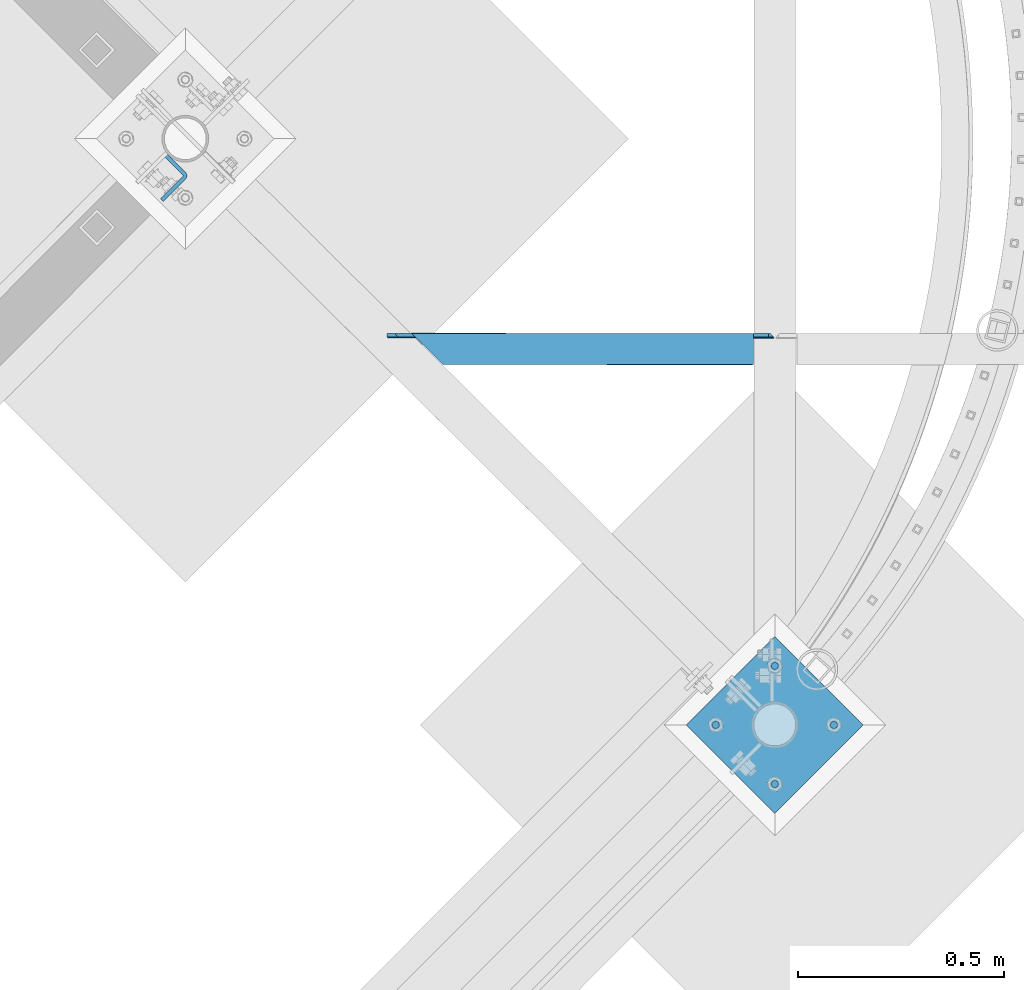
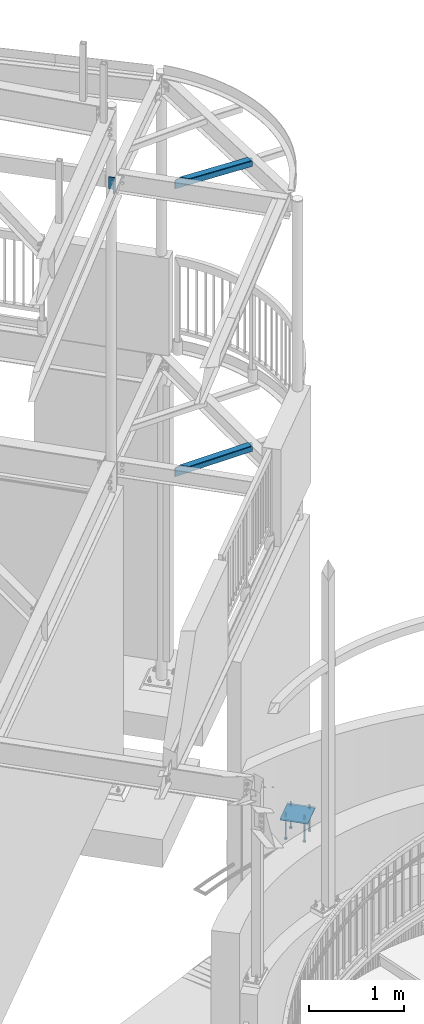
# One storey, part 520 of 975: 9 beams.
"""IFC2X3 building model written with IfcOpenShell, lengths in millimetres."""

import ifcopenshell
import ifcopenshell.guid

model = None  # the IFC model being written
_history = None  # IfcOwnerHistory: only IFC2X3 demands one
_inside = {}  # id of a spatial element -> (the spatial element, [elements in it])
_under = {}  # id of a project, library or spatial element -> (it, [spatial elements below it])
_declared = {}  # id of a project -> (the project, [libraries it declares])
_typed = {}  # id of a type object -> (the type object, [elements of that type])
_made_of = {}  # id of a material, layer set ... -> (it, [elements and type objects made of it])


def new_model(schema):
    """Start an empty IFC model of exactly this schema.

    Asked for "IFC4X3", IfcOpenShell would pick the latest addendum, in which some entities
    have other attributes; the version numbers below select the first issue.
    IFC2X3 requires an IfcOwnerHistory on every rooted entity: one is made here for all.
    """
    global model, _history
    if schema == "IFC4X3":
        model = ifcopenshell.file(schema_version=(4, 3, 0, 0))
    else:
        model = ifcopenshell.file(schema=schema)
    _inside.clear()
    _under.clear()
    _declared.clear()
    _typed.clear()
    _made_of.clear()
    _history = None
    if model.schema == "IFC2X3":
        org = make("IfcOrganization", Name="unknown")
        user = make(
            "IfcPersonAndOrganization",
            ThePerson=make("IfcPerson", FamilyName="unknown"),
            TheOrganization=org,
        )
        app = make(
            "IfcApplication",
            ApplicationDeveloper=org,
            Version="unknown",
            ApplicationFullName="unknown",
            ApplicationIdentifier="unknown",
        )
        _history = make(
            "IfcOwnerHistory",
            OwningUser=user,
            OwningApplication=app,
            ChangeAction="ADDED",
            CreationDate=0,
        )
    return model


def make(cls, **values):
    """One entity of the class cls with the attributes given. An attribute that is None is left unset."""
    return model.create_entity(
        cls, **{name: value for name, value in values.items() if value is not None}
    )


def rooted(cls, **values):
    """An entity with a GlobalId (a new one), such as an element, a storey or a relation."""
    return make(cls, GlobalId=ifcopenshell.guid.new(), OwnerHistory=_history, **values)


def si_unit(unit_type, name, prefix=None):
    """IfcSIUnit, for example si_unit("LENGTHUNIT", "METRE", prefix="MILLI")."""
    return make("IfcSIUnit", UnitType=unit_type, Prefix=prefix, Name=name)


def assignment(units):
    """IfcUnitAssignment: the units of a project."""
    return None if units is None else make("IfcUnitAssignment", Units=units)


def point(xyz):
    """IfcCartesianPoint."""
    return None if xyz is None else make("IfcCartesianPoint", Coordinates=xyz)


def direction(xyz):
    """IfcDirection."""
    return None if xyz is None else make("IfcDirection", DirectionRatios=xyz)


def frame(location, z_axis=None, x_axis=None):
    """IfcAxis2Placement3D, a coordinate frame: its origin and axes. An axis left out is left unset."""
    return make(
        "IfcAxis2Placement3D",
        Location=point(location),
        Axis=direction(z_axis),
        RefDirection=direction(x_axis),
    )


def origin_with_axes():
    """The frame at (0, 0, 0) with the z axis (0, 0, 1) and the x axis (1, 0, 0) written out."""
    return frame((0.0, 0.0, 0.0), z_axis=(0.0, 0.0, 1.0), x_axis=(1.0, 0.0, 0.0))


def place(relative_to, where):
    """IfcLocalPlacement: puts the frame where relative to a parent placement (None: the world)."""
    return make(
        "IfcLocalPlacement", PlacementRelTo=relative_to, RelativePlacement=where
    )


def context(
    kind, dimensions, precision=None, world=None, true_north=None, identifier=None
):
    """IfcGeometricRepresentationContext, for example the 3D "Model" context."""
    return make(
        "IfcGeometricRepresentationContext",
        ContextIdentifier=identifier,
        ContextType=kind,
        CoordinateSpaceDimension=dimensions,
        Precision=precision,
        WorldCoordinateSystem=world,
        TrueNorth=true_north,
    )


def subcontext(parent, identifier, kind, view, scale=None):
    """IfcGeometricRepresentationSubContext, for example "Body" below "Model"."""
    return make(
        "IfcGeometricRepresentationSubContext",
        ContextIdentifier=identifier,
        ContextType=kind,
        ParentContext=parent,
        TargetScale=scale,
        TargetView=view,
    )


def project(units=None, contexts=None):
    """IfcProject with its units and contexts."""
    return rooted(
        "IfcProject",
        Name="project",
        RepresentationContexts=contexts,
        UnitsInContext=assignment(units),
    )


def spatial(cls, under=None, at=None, **own):
    """A site, building, storey or space (cls), placed at a placement, below another one or the project."""
    s = rooted(cls, ObjectPlacement=at, **own)
    if under is not None:
        _under.setdefault(under.id(), (under, []))[1].append(s)
    return s


def faces_of(points, faces, orient=None, outer=None):
    """IfcFace entities. A face is a list of loops; a loop is a list of indices into points, from 0.

    orient and outer hold one flag for each loop. By default every Orientation is true, the
    first loop of a face is its IfcFaceOuterBound and the others are IfcFaceBound.
    """
    made = []
    for i, loops in enumerate(faces):
        bounds = []
        for j, loop in enumerate(loops):
            is_outer = j == 0 if outer is None else outer[i][j]
            bounds.append(
                make(
                    "IfcFaceOuterBound" if is_outer else "IfcFaceBound",
                    Bound=make("IfcPolyLoop", Polygon=[points[k] for k in loop]),
                    Orientation=True if orient is None else orient[i][j],
                )
            )
        made.append(make("IfcFace", Bounds=bounds))
    return made


def faceted_brep(points, faces, orient=None, outer=None, voids=None):
    """IfcFacetedBrep: a solid bounded by flat faces; with voids (closed shells), ...WithVoids."""
    shared = [point(p) for p in points]
    hull = make("IfcClosedShell", CfsFaces=faces_of(shared, faces, orient, outer))
    if voids is None:
        return make("IfcFacetedBrep", Outer=hull)
    return make(
        "IfcFacetedBrepWithVoids",
        Outer=hull,
        Voids=[
            make(cls, CfsFaces=faces_of(shared, fs, o, b)) for cls, fs, o, b in voids
        ],
    )


def shape(context_of_items, identifier, shape_type, items):
    """IfcShapeRepresentation: the items that make up one representation, for example the "Body"."""
    return make(
        "IfcShapeRepresentation",
        ContextOfItems=context_of_items,
        RepresentationIdentifier=identifier,
        RepresentationType=shape_type,
        Items=items,
    )


def material(Name=None, Category=None):
    """IfcMaterial."""
    return make("IfcMaterial", Name=Name, Category=Category)


def made_of(thing, what):
    """Note that an element or type object is made of a material, layer set ...; save() writes the relation."""
    if what is not None:
        _made_of.setdefault(what.id(), (what, []))[1].append(thing)
    return thing


def type_object(cls, material=None, **own):
    """A type object (cls), such as IfcWallType, which elements share."""
    return made_of(rooted(cls, **own), material)


def element(
    cls,
    number,
    at=None,
    inside=None,
    cuts=None,
    type_object=None,
    material=None,
    context=None,
    identifier="Body",
    shape_type=None,
    held_by="IfcProductDefinitionShape",
    body=None,
    shapes=None,
    **own,
):
    """One element of the class cls, such as IfcWall. Its Tag is "e" and its number.

    at: its placement. inside: the storey or other place that contains it. cuts: it is an
    opening in that element (IfcRelVoidsElement). A single representation is given by context,
    identifier, shape_type and body (its items); several are given by shapes. held_by: the class
    of the entity that holds the representations. save() writes the other relations.
    """
    e = rooted(cls, Tag="e%d" % number, ObjectPlacement=at, **own)
    if body is not None:
        shapes = [shape(context, identifier, shape_type, body)]
    if shapes is not None:
        e.Representation = make(held_by, Representations=shapes)
    if inside is not None:
        _inside.setdefault(inside.id(), (inside, []))[1].append(e)
    if cuts is not None:
        rooted(
            "IfcRelVoidsElement", RelatingBuildingElement=cuts, RelatedOpeningElement=e
        )
    if type_object is not None:
        _typed.setdefault(type_object.id(), (type_object, []))[1].append(e)
    return made_of(e, material)


def aggregate(whole, parts):
    """IfcRelAggregates: a whole, such as a stair, and the parts it consists of."""
    return rooted("IfcRelAggregates", RelatingObject=whole, RelatedObjects=parts)


def save(model, path):
    """Write the relations noted so far, then the file.

    IfcRelAggregates (storeys below a building ...), IfcRelContainedInSpatialStructure (elements
    in a storey), IfcRelDefinesByType, IfcRelAssociatesMaterial and IfcRelDeclares: one each for
    every whole, place, type object, material and project.
    """
    for whole, parts in _under.values():
        aggregate(whole, parts)
    for where, things in _inside.values():
        rooted(
            "IfcRelContainedInSpatialStructure",
            RelatedElements=things,
            RelatingStructure=where,
        )
    for kind, things in _typed.values():
        rooted("IfcRelDefinesByType", RelatedObjects=things, RelatingType=kind)
    for what, things in _made_of.values():
        rooted("IfcRelAssociatesMaterial", RelatedObjects=things, RelatingMaterial=what)
    for by, libraries in _declared.values():
        rooted("IfcRelDeclares", RelatingContext=by, RelatedDefinitions=libraries)
    model.write(path)


model = new_model("IFC2X3")

# Units and contexts
model_context = context("Model", 3, precision=1e-05, world=origin_with_axes())
body_context = subcontext(model_context, "Body", "Model", "MODEL_VIEW")
ifc_project = project(units=[si_unit("LENGTHUNIT", "METRE", prefix="MILLI"), si_unit("AREAUNIT", "SQUARE_METRE"), si_unit("VOLUMEUNIT", "CUBIC_METRE"), si_unit("MASSUNIT", "GRAM", prefix="KILO"), si_unit("TIMEUNIT", "SECOND"), si_unit("PLANEANGLEUNIT", "RADIAN"), si_unit("SOLIDANGLEUNIT", "STERADIAN"), si_unit("THERMODYNAMICTEMPERATUREUNIT", "DEGREE_CELSIUS"), si_unit("LUMINOUSINTENSITYUNIT", "LUMEN")], contexts=[model_context])

# Site, building, storey
site_placement = place(None, origin_with_axes())
site = spatial("IfcSite", under=ifc_project, at=site_placement, CompositionType="ELEMENT")
building_placement = place(site_placement, origin_with_axes())
building = spatial("IfcBuilding", under=site, at=building_placement, Name="Undefined", CompositionType="ELEMENT")
storey_placement = place(building_placement, origin_with_axes())
storey = spatial("IfcBuildingStorey", under=building, at=storey_placement, Name="Undefined", CompositionType="ELEMENT", Elevation=0.0)

# Beams
ifc_material_1 = material(Name="STEEL/A36")
beam_type_1 = type_object("IfcBeamType", Name="L5X3X3/8", PredefinedType="NOTDEFINED")
beam_1_placement = place(storey_placement, frame((35537.7749999864, 11155.2515974381, 3873.5), z_axis=(0.0, 0.0, -1.0), x_axis=(-0.999999999999998, 6.90000001668524e-08, 0.0)))
element("IfcBeam", 1, at=beam_1_placement, inside=storey, type_object=beam_type_1, material=ifc_material_1, Name="ANGLE", ObjectType="L5X3X3/8", context=body_context, shape_type="Brep", body=[
    faceted_brep([(11.9062518201463, 38.1000002942765, 63.5000000000409), (11.9062518201463, 38.1000000000004, -50.8000004849969), (2.38125152588327, 28.5750000000007, -41.2750001907348), (2.38125152588327, 28.5750000000007, 63.5), (52.3875000000044, -38.1000000000004, -53.9749999999999), (52.3875000000044, -38.1000000000004, -63.5), (806.831932706991, -38.1000000000004, -63.5), (806.831932706991, -38.1000000000004, -53.9749999999999), (52.3875000000044, 28.5750000000007, -53.9749999999999), (873.882778224608, 28.5750000000007, -53.9749999999999), (15.0812513351484, 28.5750000000007, -53.9749999999999), (15.0812513351484, 38.1000000000004, -53.9749999999999), (52.3875000000044, 38.1000000000004, -53.9749999999999), (52.3875000000044, 38.1000000000004, -63.5), (883.461470441413, 38.1000000000004, -63.5), (883.461470441413, 38.1000000000004, -53.9750003774025), (925.242134563909, 38.1000000000004, -51.077271348563), (915.663442347111, 28.5750000000007, -51.077271348563), (942.550496853299, 38.1000000000004, -37.6135273571017), (942.550497938631, 28.5750000000007, -30.1625003774025), (942.550496853299, 28.5750000000007, 63.5), (942.550496853299, 38.1000000000004, 63.5000000040263)], [[[0, 1, 2, 3]], [[4, 5, 6, 7]], [[8, 4, 7, 9]], [[10, 11, 12, 8]], [[4, 8, 12, 13, 5]], [[5, 13, 14, 6]], [[15, 9, 7, 6, 14]], [[16, 17, 9, 15]], [[17, 16, 18, 19]], [[20, 19, 18, 21]], [[20, 21, 0, 3]], [[10, 8, 9, 17, 19, 20, 3, 2]], [[11, 10, 2, 1]], [[21, 18, 16, 15, 14, 13, 12, 11, 1, 0]]]),
])
beam_2_placement = place(storey_placement, frame((35535.0920992425, 11153.5144184146, 7523.50181482672), z_axis=(-0.0422504062137741, -0.0209237200044117, -0.99888793221059), x_axis=(-0.999107052910133, 0.000884825999921025, 0.0422411399962006)))
element("IfcBeam", 2, at=beam_2_placement, inside=storey, type_object=beam_type_1, material=ifc_material_1, Name="ANGLE", ObjectType="L5X3X3/8", context=body_context, shape_type="Brep", body=[
    faceted_brep([(941.742880196944, 38.0999993124042, -35.9725623119593), (937.536367839362, 38.1000000003914, 63.5000000001819), (937.536368026471, 28.5750000003973, 63.5000000001783), (941.457524557751, 28.5750000004664, -29.2247304156172), (53.4452887239022, -38.0999999999149, -53.9750000000258), (53.8480835175287, -38.0999999999094, -63.5000000000291), (807.064276355675, -38.099999999542, -63.4999999999145), (807.06427633432, -38.0999999995493, -53.9749999999094), (53.4452887390871, 28.5750000000535, -53.9750000000022), (874.050649366603, 28.5750000004518, -53.9749999998785), (48.4726977129612, 28.5749999999625, 63.50000000004), (48.4726978208564, 38.0999999999567, 63.5000000000437), (6.6211369338489, 38.0999999999403, 61.7301741910833), (-2.89535803997569, 28.5749999999389, 61.3277390639887), (11.2222354366604, 38.1000002997298, -47.0732759403381), (1.30330533162487, 28.5750000000153, -37.9592161034652), (13.6967584280574, 38.1000000000258, -49.3470040937027), (13.696758414997, 28.5750000000298, -49.3470040896955), (53.1789736611245, 38.100000000044, -47.6773735700881), (53.1789736587452, 28.575000000048, -47.6773735656316), (53.8480835348819, 38.1000000000568, -63.5000000000036), (883.62013121794, 38.1000000004587, -63.4999999998763), (883.620131173593, 38.0999999520591, -50.7375928477722), (874.050649363482, 28.57500000045, -51.1422686872647), (924.840126222451, 38.0999999463384, -48.9944748163671), (915.270644418095, 28.5750000004682, -49.3991506556158)], [[[0, 1, 2, 3]], [[4, 5, 6, 7]], [[8, 4, 7, 9]], [[10, 11, 12, 13]], [[14, 15, 13, 12]], [[16, 17, 15, 14]], [[18, 19, 17, 16]], [[5, 4, 8, 19, 18, 20]], [[5, 20, 21, 6]], [[22, 23, 9, 7, 6, 21]], [[24, 25, 23, 22]], [[25, 24, 0, 3]], [[10, 13, 15, 17, 19, 8, 9, 23, 25, 3, 2]], [[11, 10, 2, 1]], [[24, 22, 21, 20, 18, 16, 14, 12, 11, 1, 0]]]),
])
beam_type_2 = type_object("IfcBeamType", PredefinedType="NOTDEFINED")
beam_3_placement = place(storey_placement, frame((34052.9424595516, 11630.2526601364, 7499.36613405322), z_axis=(0.0, 0.0, 1.0), x_axis=(0.709329753904792, -0.704876797905398, 0.0)))
element("IfcBeam", 3, at=beam_3_placement, inside=storey, type_object=beam_type_2, material=ifc_material_1, Name="PLATE", context=body_context, shape_type="Brep", body=[
    faceted_brep([(-1.26819941215217e-07, 4.76250000000437, -76.1999999999998), (-1.26819941215217e-07, 4.76250000000437, 76.1999999999998), (67.9764954378516, 4.76250083879131, 76.1999999999998), (67.9764954378516, 4.76250083879131, -76.1999999999998), (1.26819941215217e-07, -4.762500000008, 76.1999999999998), (1.26819941215217e-07, -4.762500000008, -76.1999999999998), (67.9764955554074, -4.76249916121378, -76.1999999999998), (67.9764955554074, -4.76249916121378, 76.1999999999998), (74.3264952113022, 3.0610236584871, 76.1999999999998), (74.3264952113022, 3.0610236584871, -76.1999999999998), (69.5639954269482, -5.18786843704584, -76.1999999999998), (69.5639954269482, -5.18786843704584, 76.1999999999998), (70.7261260223277, -6.34999895563669, -76.1999999999998), (70.7261260223277, -6.34999895563669, 76.1999999999998), (78.9750178031391, -1.58749862619516, 76.1999999999998), (78.9750178031391, -1.58749862619516, -76.1999999999998), (71.1514954030572, -7.93749879907409, -76.1999999999998), (71.1514954030572, -7.93749879907409, 76.1999999999998), (80.6764954030332, -7.93749828724685, 76.1999999999998), (80.6764954030332, -7.93749828724685, -76.1999999999998), (80.6764994978694, -84.1374983053538, 76.1999999999998), (80.6764994978694, -84.1374983053538, -76.1999999999998), (71.1514994978879, -84.137498817181, 76.1999999999998), (71.1514994978879, -84.137498817181, -76.1999999999998)], [[[0, 1, 2, 3]], [[4, 5, 6, 7]], [[5, 4, 1, 0]], [[3, 2, 8, 9]], [[7, 6, 10, 11]], [[10, 12, 13, 11]], [[8, 14, 15, 9]], [[12, 16, 17, 13]], [[14, 18, 19, 15]], [[19, 18, 20, 21]], [[18, 14, 8, 2, 1, 4, 7, 11, 13, 17, 22, 20]], [[17, 16, 23, 22]], [[16, 12, 10, 6, 5, 0, 3, 9, 15, 19, 21, 23]], [[22, 23, 21, 20]]]),
])
beam_type_3 = type_object("IfcBeamType", PredefinedType="NOTDEFINED")
beam_4_placement = place(storey_placement, frame((35645.5380734525, 10133.1994265471, -257.175000000002), z_axis=(-0.707106781186548, -0.707106781186548, 0.0), x_axis=(-0.707106781186601, 0.707106781186494, 2.36468622460961e-14)))
element("IfcBeam", 4, at=beam_4_placement, inside=storey, type_object=beam_type_3, material=ifc_material_1, Name="PLATE", context=body_context, shape_type="Brep", body=[
    faceted_brep([(0.0, 9.52499999999964, -152.4), (0.0, 9.52499999999964, 152.4), (304.799999999152, 9.52499999999964, 152.4), (304.799999999152, 9.52499999999964, -152.4), (0.0, -9.52499999999964, 152.4), (304.799999999152, -9.52499999999964, 152.4), (0.0, -9.52499999999964, -152.4), (304.799999999152, -9.52499999999964, -152.4)], [[[0, 1, 2, 3]], [[1, 4, 5, 2]], [[4, 6, 7, 5]], [[6, 0, 3, 7]], [[5, 7, 3, 2]], [[6, 4, 1, 0]]]),
])
ifc_material_2 = material(Name="STEEL/F1554-36")
beam_type_4 = type_object("IfcBeamType", PredefinedType="NOTDEFINED")
beam_5_placement = place(storey_placement, frame((35681.4590946999, 10240.962501079, -304.799999999999), z_axis=(-0.707106781186601, 0.707106781186494, 2.36468622460961e-14), x_axis=(0.0, 0.0, -1.0)))
element("IfcBeam", 5, at=beam_5_placement, inside=storey, type_object=beam_type_4, material=ifc_material_2, Name="HEADED_ANCHOR_BOLT", context=body_context, shape_type="Brep", body=[
    faceted_brep([(209.543749999999, -9.13000011446275, 15.8100004196049), (209.543749999999, -18.2600002288382, 4.72937244921923e-11), (228.593749999998, -18.2600002288382, 4.72937244921923e-11), (228.593749999998, -9.13000011446275, 15.8100004196049), (209.543749999999, 9.13000011438271, 15.8100004195576), (228.593749999998, 9.13000011438271, 15.8100004195576), (209.543749999999, 18.2600002288382, -4.72937244921923e-11), (228.593749999998, 18.2600002288382, -4.72937244921923e-11), (209.543749999999, 9.13000011446275, -15.8100004196049), (228.593749999998, 9.13000011446275, -15.8100004196049), (209.543749999999, -9.13000011438271, -15.8100004195576), (228.593749999998, -9.13000011438271, -15.8100004195576), (209.543749999999, -4.4776800552936, 9.29799844178979), (209.543749999999, -8.068500660469, 6.43441456491473), (209.543749999999, -10.0612557561763, 2.2964159705416), (209.543749999999, -10.0612557561617, -2.29641597048976), (209.543749999999, -8.0685006604399, -6.4344145648729), (209.543749999999, -4.47768005524995, -9.29799844176705), (209.543749999999, 2.91038304567337e-11, -10.3199996948015), (209.543749999999, 4.4776800552936, -9.29799844178979), (209.543749999999, 8.068500660469, -6.43441456491473), (209.543749999999, 10.0612557561763, -2.2964159705416), (209.543749999999, 10.0612557561617, 2.29641597048976), (209.543749999999, 8.0685006604399, 6.4344145648729), (209.543749999999, 4.47768005524995, 9.29799844176705), (209.543749999999, -2.91038304567337e-11, 10.3199996948015), (228.593749999998, -2.91038304567337e-11, 10.3199996948015), (228.593749999998, -4.4776800552936, 9.29799844178979), (228.593749999998, -8.068500660469, 6.43441456491473), (228.593749999998, -10.0612557561763, 2.2964159705416), (228.593749999998, -10.0612557561617, -2.29641597048976), (228.593749999998, -8.0685006604399, -6.4344145648729), (228.593749999998, -4.47768005524995, -9.29799844176705), (228.593749999998, 2.91038304567337e-11, -10.3199996948015), (228.593749999998, 4.4776800552936, -9.29799844178979), (228.593749999998, 8.068500660469, -6.43441456491473), (228.593749999998, 10.0612557561763, -2.2964159705416), (228.593749999998, 10.0612557561617, 2.29641597048976), (228.593749999998, 8.0685006604399, 6.4344145648729), (228.593749999998, 4.47768005524995, 9.29799844176705), (0.0, -6.73519209080223, 6.73519209080186), (0.0, -9.52499999999964, 0.0), (228.6, -9.52500000000146, 0.0), (228.6, -6.73519209080405, 6.73519209080223), (-9.87109982941227e-13, -1.20792265079217e-13, 9.52499961853027), (228.6, 0.0, 9.52499999999964), (0.0, 6.73519209080223, 6.73519209080186), (228.6, 6.73519209080405, 6.73519209080223), (0.0, 9.52499999999964, 0.0), (228.6, 9.52500000000146, 0.0), (0.0, 6.73519209080223, -6.73519209080186), (228.6, 6.73519209080405, -6.73519209080223), (2.95075507493764e-12, -1.20792265079217e-13, -9.52499961853027), (228.6, 0.0, -9.52499999999964), (-114.297914995421, -6.36396103067818, 6.36396103068091), (-114.297914995421, -2.18278728425503e-11, 8.99999999997999), (-114.297914995421, 6.36396103064908, 6.36396103064817), (-114.297914995421, 8.99999999997817, -2.27373675443232e-11), (-114.297914995421, 6.36396103067818, -6.36396103068091), (-114.297914995421, 2.18278728425503e-11, -8.99999999997999), (-114.297914995421, -6.36396103064908, -6.36396103064817), (-114.297914995421, -8.99999999997817, 2.27373675443232e-11), (0.0149743263646087, 6.36396103067818, -6.36396103067909), (0.0149743263646087, 0.0, -9.0), (0.0149743263646087, -6.36396103067818, -6.36396103067909), (0.0149743263987148, -8.9999995411581, -1.00796984270346e-06), (0.0149743263646087, -6.36396103067818, 6.36396103067909), (0.0149743263646087, 0.0, 9.0), (0.0149743263646087, 6.36396103067818, 6.36396103067909), (0.0149743263987148, 9.0000004588419, -1.00796984270346e-06), (0.0, -6.73519209080223, -6.73519209080186), (228.6, -6.73519209080405, -6.73519209080223)], [[[0, 1, 2, 3]], [[4, 0, 3, 5]], [[6, 4, 5, 7]], [[8, 6, 7, 9]], [[10, 8, 9, 11]], [[0, 4, 6, 8, 10, 1], [12, 13, 14, 15, 16, 17, 18, 19, 20, 21, 22, 23, 24, 25]], [[12, 25, 26, 27]], [[13, 12, 27, 28]], [[14, 13, 28, 29]], [[15, 14, 29, 30]], [[16, 15, 30, 31]], [[17, 16, 31, 32]], [[18, 17, 32, 33]], [[19, 18, 33, 34]], [[20, 19, 34, 35]], [[21, 20, 35, 36]], [[22, 21, 36, 37]], [[23, 22, 37, 38]], [[24, 23, 38, 39]], [[25, 24, 39, 26]], [[9, 7, 5, 3, 2, 11], [38, 37, 36, 35, 34, 33, 32, 31, 30, 29, 28, 27, 26, 39]], [[1, 10, 11, 2]], [[40, 41, 42, 43]], [[44, 40, 43, 45]], [[46, 44, 45, 47]], [[48, 46, 47, 49]], [[50, 48, 49, 51]], [[52, 50, 51, 53]], [[54, 55, 56, 57, 58, 59, 60, 61]], [[59, 58, 62, 63]], [[60, 59, 63, 64]], [[61, 60, 64, 65]], [[54, 61, 65, 66]], [[55, 54, 66, 67]], [[56, 55, 67, 68]], [[57, 56, 68, 69]], [[58, 57, 69, 62]], [[40, 44, 46, 48, 50, 52, 70, 41], [68, 67, 66, 65, 64, 63, 62, 69]], [[41, 70, 71, 42]], [[53, 51, 49, 47, 45, 43, 42, 71]], [[70, 52, 53, 71]]]),
])
beam_6_placement = place(storey_placement, frame((35537.774998921, 10097.2784052998, -304.799999999999), z_axis=(-0.707106781186601, 0.707106781186494, 2.36468622460961e-14), x_axis=(0.0, 0.0, -1.0)))
element("IfcBeam", 6, at=beam_6_placement, inside=storey, type_object=beam_type_4, material=ifc_material_2, Name="HEADED_ANCHOR_BOLT", context=body_context, shape_type="Brep", body=[
    faceted_brep([(209.543749999999, 9.13000011446275, -15.8100004196049), (209.543749999999, 18.2600002288382, -4.72937244921923e-11), (228.593749999998, 18.2600002288382, -4.72937244921923e-11), (228.593749999998, 9.13000011446275, -15.8100004196049), (209.543749999999, -9.13000011438271, -15.8100004195576), (228.593749999998, -9.13000011438271, -15.8100004195576), (209.543749999999, -18.2600002288382, 4.72937244921923e-11), (228.593749999998, -18.2600002288382, 4.72937244921923e-11), (209.543749999999, -9.13000011446275, 15.8100004196049), (228.593749999998, -9.13000011446275, 15.8100004196049), (209.543749999999, 9.13000011438271, 15.8100004195576), (228.593749999998, 9.13000011438271, 15.8100004195576), (209.543749999999, -4.4776800552936, 9.29799844178979), (209.543749999999, -8.068500660469, 6.43441456491473), (209.543749999999, -10.0612557561763, 2.2964159705416), (209.543749999999, -10.0612557561617, -2.29641597048976), (209.543749999999, -8.0685006604399, -6.4344145648729), (209.543749999999, -4.47768005524995, -9.29799844176705), (209.543749999999, 2.91038304567337e-11, -10.3199996948015), (209.543749999999, 4.4776800552936, -9.29799844178979), (209.543749999999, 8.068500660469, -6.43441456491473), (209.543749999999, 10.0612557561763, -2.2964159705416), (209.543749999999, 10.0612557561617, 2.29641597048976), (209.543749999999, 8.0685006604399, 6.4344145648729), (209.543749999999, 4.47768005524995, 9.29799844176705), (209.543749999999, -2.91038304567337e-11, 10.3199996948015), (228.593749999998, 2.91038304567337e-11, -10.3199996948015), (228.593749999998, 4.4776800552936, -9.29799844178979), (228.593749999998, 8.068500660469, -6.43441456491473), (228.593749999998, 10.0612557561763, -2.2964159705416), (228.593749999998, 10.0612557561617, 2.29641597048976), (228.593749999998, 8.0685006604399, 6.4344145648729), (228.593749999998, 4.47768005524995, 9.29799844176705), (228.593749999998, -2.91038304567337e-11, 10.3199996948015), (228.593749999998, -4.4776800552936, 9.29799844178979), (228.593749999998, -8.068500660469, 6.43441456491473), (228.593749999998, -10.0612557561763, 2.2964159705416), (228.593749999998, -10.0612557561617, -2.29641597048976), (228.593749999998, -8.0685006604399, -6.4344145648729), (228.593749999998, -4.47768005524995, -9.29799844176705), (0.0, -6.73519209080223, 6.73519209080186), (0.0, -9.52499999999964, 0.0), (228.6, -9.52500000000146, 0.0), (228.6, -6.73519209080405, 6.73519209080223), (-9.87109982941227e-13, -1.20792265079217e-13, 9.52499961853027), (228.6, 0.0, 9.52499999999964), (0.0, 6.73519209080223, 6.73519209080186), (228.6, 6.73519209080405, 6.73519209080223), (0.0, 9.52499999999964, 0.0), (228.6, 9.52500000000146, 0.0), (0.0, 6.73519209080223, -6.73519209080186), (228.6, 6.73519209080405, -6.73519209080223), (2.95075507493764e-12, -1.20792265079217e-13, -9.52499961853027), (228.6, 0.0, -9.52499999999964), (-114.297914995421, -6.36396103067818, 6.36396103068091), (-114.297914995421, -2.18278728425503e-11, 8.99999999997999), (-114.297914995421, 6.36396103064908, 6.36396103064817), (-114.297914995421, 8.99999999997817, -2.27373675443232e-11), (-114.297914995421, 6.36396103067818, -6.36396103068091), (-114.297914995421, 2.18278728425503e-11, -8.99999999997999), (-114.297914995421, -6.36396103064908, -6.36396103064817), (-114.297914995421, -8.99999999997817, 2.27373675443232e-11), (0.0149743263646087, 6.36396103067818, -6.36396103067909), (0.0149743263646087, 0.0, -9.0), (0.0149743263646087, -6.36396103067818, -6.36396103067909), (0.0149743263987148, -8.9999995411581, -1.00796984270346e-06), (0.0149743263646087, -6.36396103067818, 6.36396103067909), (0.0149743263646087, 0.0, 9.0), (0.0149743263646087, 6.36396103067818, 6.36396103067909), (0.0149743263987148, 9.0000004588419, -1.00796984270346e-06), (0.0, -6.73519209080223, -6.73519209080186), (228.6, -6.73519209080405, -6.73519209080223)], [[[0, 1, 2, 3]], [[4, 0, 3, 5]], [[6, 4, 5, 7]], [[8, 6, 7, 9]], [[10, 8, 9, 11]], [[8, 10, 1, 0, 4, 6], [12, 13, 14, 15, 16, 17, 18, 19, 20, 21, 22, 23, 24, 25]], [[19, 18, 26, 27]], [[20, 19, 27, 28]], [[21, 20, 28, 29]], [[22, 21, 29, 30]], [[23, 22, 30, 31]], [[24, 23, 31, 32]], [[25, 24, 32, 33]], [[12, 25, 33, 34]], [[13, 12, 34, 35]], [[14, 13, 35, 36]], [[15, 14, 36, 37]], [[16, 15, 37, 38]], [[17, 16, 38, 39]], [[18, 17, 39, 26]], [[3, 2, 11, 9, 7, 5], [31, 30, 29, 28, 27, 26, 39, 38, 37, 36, 35, 34, 33, 32]], [[1, 10, 11, 2]], [[40, 41, 42, 43]], [[44, 40, 43, 45]], [[46, 44, 45, 47]], [[48, 46, 47, 49]], [[50, 48, 49, 51]], [[52, 50, 51, 53]], [[54, 55, 56, 57, 58, 59, 60, 61]], [[59, 58, 62, 63]], [[60, 59, 63, 64]], [[61, 60, 64, 65]], [[54, 61, 65, 66]], [[55, 54, 66, 67]], [[56, 55, 67, 68]], [[57, 56, 68, 69]], [[58, 57, 69, 62]], [[40, 44, 46, 48, 50, 52, 70, 41], [68, 67, 66, 65, 64, 63, 62, 69]], [[41, 70, 71, 42]], [[53, 51, 49, 47, 45, 43, 42, 71]], [[70, 52, 53, 71]]]),
])
beam_7_placement = place(storey_placement, frame((35394.0909031422, 10240.962501079, -304.799999999999), z_axis=(-0.707106781186601, 0.707106781186494, 2.36468622460961e-14), x_axis=(0.0, 0.0, -1.0)))
element("IfcBeam", 7, at=beam_7_placement, inside=storey, type_object=beam_type_4, material=ifc_material_2, Name="HEADED_ANCHOR_BOLT", context=body_context, shape_type="Brep", body=[
    faceted_brep([(209.543749999999, 9.13000011446275, -15.8100004196049), (209.543749999999, 18.2600002288382, -4.72937244921923e-11), (228.593749999998, 18.2600002288382, -4.72937244921923e-11), (228.593749999998, 9.13000011446275, -15.8100004196049), (209.543749999999, -9.13000011438271, -15.8100004195576), (228.593749999998, -9.13000011438271, -15.8100004195576), (209.543749999999, -18.2600002288382, 4.72937244921923e-11), (228.593749999998, -18.2600002288382, 4.72937244921923e-11), (209.543749999999, -9.13000011446275, 15.8100004196049), (228.593749999998, -9.13000011446275, 15.8100004196049), (209.543749999999, 9.13000011438271, 15.8100004195576), (228.593749999998, 9.13000011438271, 15.8100004195576), (209.543749999999, -4.4776800552936, 9.29799844178979), (209.543749999999, -8.068500660469, 6.43441456491473), (209.543749999999, -10.0612557561763, 2.2964159705416), (209.543749999999, -10.0612557561617, -2.29641597048976), (209.543749999999, -8.0685006604399, -6.4344145648729), (209.543749999999, -4.47768005524995, -9.29799844176705), (209.543749999999, 2.91038304567337e-11, -10.3199996948015), (209.543749999999, 4.4776800552936, -9.29799844178979), (209.543749999999, 8.068500660469, -6.43441456491473), (209.543749999999, 10.0612557561763, -2.2964159705416), (209.543749999999, 10.0612557561617, 2.29641597048976), (209.543749999999, 8.0685006604399, 6.4344145648729), (209.543749999999, 4.47768005524995, 9.29799844176705), (209.543749999999, -2.91038304567337e-11, 10.3199996948015), (228.593749999998, 2.91038304567337e-11, -10.3199996948015), (228.593749999998, 4.4776800552936, -9.29799844178979), (228.593749999998, 8.068500660469, -6.43441456491473), (228.593749999998, 10.0612557561763, -2.2964159705416), (228.593749999998, 10.0612557561617, 2.29641597048976), (228.593749999998, 8.0685006604399, 6.4344145648729), (228.593749999998, 4.47768005524995, 9.29799844176705), (228.593749999998, -2.91038304567337e-11, 10.3199996948015), (228.593749999998, -4.4776800552936, 9.29799844178979), (228.593749999998, -8.068500660469, 6.43441456491473), (228.593749999998, -10.0612557561763, 2.2964159705416), (228.593749999998, -10.0612557561617, -2.29641597048976), (228.593749999998, -8.0685006604399, -6.4344145648729), (228.593749999998, -4.47768005524995, -9.29799844176705), (0.0, -6.73519209080223, 6.73519209080186), (0.0, -9.52499999999964, 0.0), (228.6, -9.52500000000146, 0.0), (228.6, -6.73519209080405, 6.73519209080223), (-9.87109982941227e-13, -1.20792265079217e-13, 9.52499961853027), (228.6, 0.0, 9.52499999999964), (0.0, 6.73519209080223, 6.73519209080186), (228.6, 6.73519209080405, 6.73519209080223), (0.0, 9.52499999999964, 0.0), (228.6, 9.52500000000146, 0.0), (0.0, 6.73519209080223, -6.73519209080186), (228.6, 6.73519209080405, -6.73519209080223), (2.95075507493764e-12, -1.20792265079217e-13, -9.52499961853027), (228.6, 0.0, -9.52499999999964), (-114.297914995421, -6.36396103067818, 6.36396103068091), (-114.297914995421, -2.18278728425503e-11, 8.99999999997999), (-114.297914995421, 6.36396103064908, 6.36396103064817), (-114.297914995421, 8.99999999997817, -2.27373675443232e-11), (-114.297914995421, 6.36396103067818, -6.36396103068091), (-114.297914995421, 2.18278728425503e-11, -8.99999999997999), (-114.297914995421, -6.36396103064908, -6.36396103064817), (-114.297914995421, -8.99999999997817, 2.27373675443232e-11), (0.0149743263646087, 6.36396103067818, -6.36396103067909), (0.0149743263646087, 0.0, -9.0), (0.0149743263646087, -6.36396103067818, -6.36396103067909), (0.0149743263987148, -8.9999995411581, -1.00796984270346e-06), (0.0149743263646087, -6.36396103067818, 6.36396103067909), (0.0149743263646087, 0.0, 9.0), (0.0149743263646087, 6.36396103067818, 6.36396103067909), (0.0149743263987148, 9.0000004588419, -1.00796984270346e-06), (0.0, -6.73519209080223, -6.73519209080186), (228.6, -6.73519209080405, -6.73519209080223)], [[[0, 1, 2, 3]], [[4, 0, 3, 5]], [[6, 4, 5, 7]], [[8, 6, 7, 9]], [[10, 8, 9, 11]], [[8, 10, 1, 0, 4, 6], [12, 13, 14, 15, 16, 17, 18, 19, 20, 21, 22, 23, 24, 25]], [[19, 18, 26, 27]], [[20, 19, 27, 28]], [[21, 20, 28, 29]], [[22, 21, 29, 30]], [[23, 22, 30, 31]], [[24, 23, 31, 32]], [[25, 24, 32, 33]], [[12, 25, 33, 34]], [[13, 12, 34, 35]], [[14, 13, 35, 36]], [[15, 14, 36, 37]], [[16, 15, 37, 38]], [[17, 16, 38, 39]], [[18, 17, 39, 26]], [[3, 2, 11, 9, 7, 5], [31, 30, 29, 28, 27, 26, 39, 38, 37, 36, 35, 34, 33, 32]], [[1, 10, 11, 2]], [[40, 41, 42, 43]], [[44, 40, 43, 45]], [[46, 44, 45, 47]], [[48, 46, 47, 49]], [[50, 48, 49, 51]], [[52, 50, 51, 53]], [[54, 55, 56, 57, 58, 59, 60, 61]], [[59, 58, 62, 63]], [[60, 59, 63, 64]], [[61, 60, 64, 65]], [[54, 61, 65, 66]], [[55, 54, 66, 67]], [[56, 55, 67, 68]], [[57, 56, 68, 69]], [[58, 57, 69, 62]], [[40, 44, 46, 48, 50, 52, 70, 41], [68, 67, 66, 65, 64, 63, 62, 69]], [[41, 70, 71, 42]], [[53, 51, 49, 47, 45, 43, 42, 71]], [[70, 52, 53, 71]]]),
])
beam_8_placement = place(storey_placement, frame((35537.774998921, 10384.6465968582, -304.799999999999), z_axis=(-0.707106781186601, 0.707106781186494, 2.36468622460961e-14), x_axis=(0.0, 0.0, -1.0)))
element("IfcBeam", 8, at=beam_8_placement, inside=storey, type_object=beam_type_4, material=ifc_material_2, Name="HEADED_ANCHOR_BOLT", context=body_context, shape_type="Brep", body=[
    faceted_brep([(209.543749999999, -9.13000011446275, 15.8100004196049), (209.543749999999, -18.2600002288382, 4.72937244921923e-11), (228.593749999998, -18.2600002288382, 4.72937244921923e-11), (228.593749999998, -9.13000011446275, 15.8100004196049), (209.543749999999, 9.13000011438271, 15.8100004195576), (228.593749999998, 9.13000011438271, 15.8100004195576), (209.543749999999, 18.2600002288382, -4.72937244921923e-11), (228.593749999998, 18.2600002288382, -4.72937244921923e-11), (209.543749999999, 9.13000011446275, -15.8100004196049), (228.593749999998, 9.13000011446275, -15.8100004196049), (209.543749999999, -9.13000011438271, -15.8100004195576), (228.593749999998, -9.13000011438271, -15.8100004195576), (209.543749999999, -4.4776800552936, 9.29799844178979), (209.543749999999, -8.068500660469, 6.43441456491473), (209.543749999999, -10.0612557561763, 2.2964159705416), (209.543749999999, -10.0612557561617, -2.29641597048976), (209.543749999999, -8.0685006604399, -6.4344145648729), (209.543749999999, -4.47768005524995, -9.29799844176705), (209.543749999999, 2.91038304567337e-11, -10.3199996948015), (209.543749999999, 4.4776800552936, -9.29799844178979), (209.543749999999, 8.068500660469, -6.43441456491473), (209.543749999999, 10.0612557561763, -2.2964159705416), (209.543749999999, 10.0612557561617, 2.29641597048976), (209.543749999999, 8.0685006604399, 6.4344145648729), (209.543749999999, 4.47768005524995, 9.29799844176705), (209.543749999999, -2.91038304567337e-11, 10.3199996948015), (228.593749999998, -2.91038304567337e-11, 10.3199996948015), (228.593749999998, -4.4776800552936, 9.29799844178979), (228.593749999998, -8.068500660469, 6.43441456491473), (228.593749999998, -10.0612557561763, 2.2964159705416), (228.593749999998, -10.0612557561617, -2.29641597048976), (228.593749999998, -8.0685006604399, -6.4344145648729), (228.593749999998, -4.47768005524995, -9.29799844176705), (228.593749999998, 2.91038304567337e-11, -10.3199996948015), (228.593749999998, 4.4776800552936, -9.29799844178979), (228.593749999998, 8.068500660469, -6.43441456491473), (228.593749999998, 10.0612557561763, -2.2964159705416), (228.593749999998, 10.0612557561617, 2.29641597048976), (228.593749999998, 8.0685006604399, 6.4344145648729), (228.593749999998, 4.47768005524995, 9.29799844176705), (0.0, -6.73519209080223, 6.73519209080186), (0.0, -9.52499999999964, 0.0), (228.6, -9.52500000000146, 0.0), (228.6, -6.73519209080405, 6.73519209080223), (-9.87109982941227e-13, -1.20792265079217e-13, 9.52499961853027), (228.6, 0.0, 9.52499999999964), (0.0, 6.73519209080223, 6.73519209080186), (228.6, 6.73519209080405, 6.73519209080223), (0.0, 9.52499999999964, 0.0), (228.6, 9.52500000000146, 0.0), (0.0, 6.73519209080223, -6.73519209080186), (228.6, 6.73519209080405, -6.73519209080223), (2.95075507493764e-12, -1.20792265079217e-13, -9.52499961853027), (228.6, 0.0, -9.52499999999964), (-114.297914995421, -6.36396103067818, 6.36396103068091), (-114.297914995421, -2.18278728425503e-11, 8.99999999997999), (-114.297914995421, 6.36396103064908, 6.36396103064817), (-114.297914995421, 8.99999999997817, -2.27373675443232e-11), (-114.297914995421, 6.36396103067818, -6.36396103068091), (-114.297914995421, 2.18278728425503e-11, -8.99999999997999), (-114.297914995421, -6.36396103064908, -6.36396103064817), (-114.297914995421, -8.99999999997817, 2.27373675443232e-11), (0.0149743263646087, 6.36396103067818, -6.36396103067909), (0.0149743263646087, 0.0, -9.0), (0.0149743263646087, -6.36396103067818, -6.36396103067909), (0.0149743263987148, -8.9999995411581, -1.00796984270346e-06), (0.0149743263646087, -6.36396103067818, 6.36396103067909), (0.0149743263646087, 0.0, 9.0), (0.0149743263646087, 6.36396103067818, 6.36396103067909), (0.0149743263987148, 9.0000004588419, -1.00796984270346e-06), (0.0, -6.73519209080223, -6.73519209080186), (228.6, -6.73519209080405, -6.73519209080223)], [[[0, 1, 2, 3]], [[4, 0, 3, 5]], [[6, 4, 5, 7]], [[8, 6, 7, 9]], [[10, 8, 9, 11]], [[0, 4, 6, 8, 10, 1], [12, 13, 14, 15, 16, 17, 18, 19, 20, 21, 22, 23, 24, 25]], [[12, 25, 26, 27]], [[13, 12, 27, 28]], [[14, 13, 28, 29]], [[15, 14, 29, 30]], [[16, 15, 30, 31]], [[17, 16, 31, 32]], [[18, 17, 32, 33]], [[19, 18, 33, 34]], [[20, 19, 34, 35]], [[21, 20, 35, 36]], [[22, 21, 36, 37]], [[23, 22, 37, 38]], [[24, 23, 38, 39]], [[25, 24, 39, 26]], [[9, 7, 5, 3, 2, 11], [38, 37, 36, 35, 34, 33, 32, 31, 30, 29, 28, 27, 26, 39]], [[1, 10, 11, 2]], [[40, 41, 42, 43]], [[44, 40, 43, 45]], [[46, 44, 45, 47]], [[48, 46, 47, 49]], [[50, 48, 49, 51]], [[52, 50, 51, 53]], [[54, 55, 56, 57, 58, 59, 60, 61]], [[59, 58, 62, 63]], [[60, 59, 63, 64]], [[61, 60, 64, 65]], [[54, 61, 65, 66]], [[55, 54, 66, 67]], [[56, 55, 67, 68]], [[57, 56, 68, 69]], [[58, 57, 69, 62]], [[40, 44, 46, 48, 50, 52, 70, 41], [68, 67, 66, 65, 64, 63, 62, 69]], [[41, 70, 71, 42]], [[53, 51, 49, 47, 45, 43, 42, 71]], [[70, 52, 53, 71]]]),
])
beam_type_5 = type_object("IfcBeamType", PredefinedType="NOTDEFINED")
beam_9_placement = place(storey_placement, frame((35645.5380734525, 10133.1994265471, -265.112500000001), z_axis=(-0.707106781186548, -0.707106781186548, 0.0), x_axis=(-0.707106781186601, 0.707106781186494, 2.36468622460961e-14)))
element("IfcBeam", 9, at=beam_9_placement, inside=storey, type_object=beam_type_5, material=ifc_material_1, Name="TEMPLATE", context=body_context, shape_type="Brep", body=[
    faceted_brep([(0.0, 1.58750000000009, -152.4), (0.0, 1.58750000000009, 152.4), (304.799999999153, 1.58750000000001, 152.400000000001), (304.799999999153, 1.58750000000001, -152.400000000001), (0.0, -1.58750000000009, 152.4), (304.799999999153, -1.58750000000001, 152.400000000001), (0.0, -1.58750000000009, -152.4), (304.799999999153, -1.58750000000001, -152.400000000001)], [[[0, 1, 2, 3]], [[1, 4, 5, 2]], [[4, 6, 7, 5]], [[6, 0, 3, 7]], [[5, 7, 3, 2]], [[6, 4, 1, 0]]]),
])

save(model, "model.ifc")
